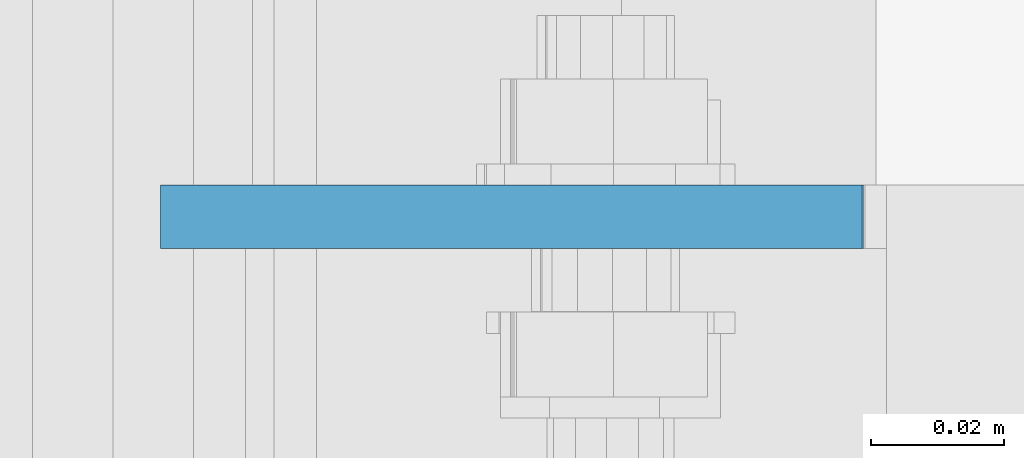
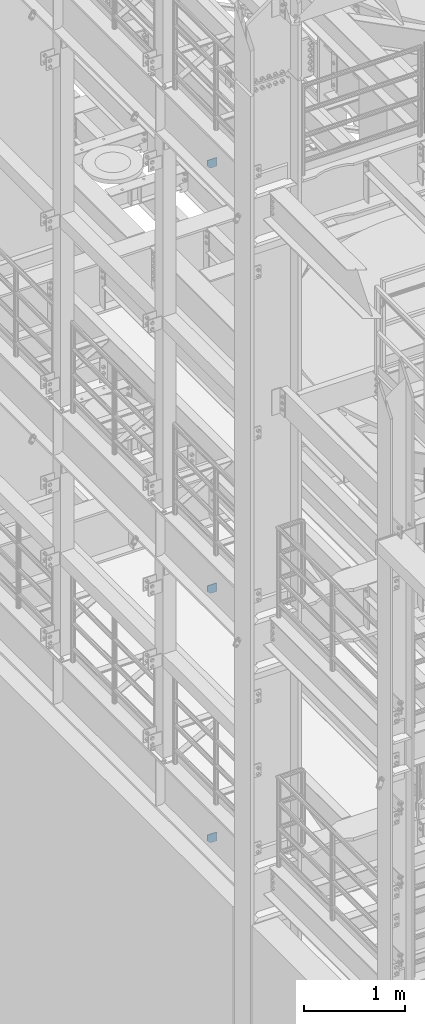
# One storey, part 1477 of 1876: 3 plates, 3 elements without a shape of their own.
"""IFC2X3 building model written with IfcOpenShell, lengths in millimetres."""

from ifc_helpers import new_model, si_unit, frame, origin_with_axes, place, context, subcontext, project, spatial, faceted_brep, material, type_object, element, aggregate, save


model = new_model("IFC2X3")

# Units and contexts
model_context = context("Model", 3, precision=1e-05, world=origin_with_axes())
body_context = subcontext(model_context, "Body", "Model", "MODEL_VIEW")
ifc_project = project(units=[si_unit("LENGTHUNIT", "METRE", prefix="MILLI"), si_unit("AREAUNIT", "SQUARE_METRE"), si_unit("VOLUMEUNIT", "CUBIC_METRE"), si_unit("MASSUNIT", "GRAM", prefix="KILO"), si_unit("TIMEUNIT", "SECOND"), si_unit("PLANEANGLEUNIT", "RADIAN"), si_unit("SOLIDANGLEUNIT", "STERADIAN"), si_unit("THERMODYNAMICTEMPERATUREUNIT", "DEGREE_CELSIUS"), si_unit("LUMINOUSINTENSITYUNIT", "LUMEN")], contexts=[model_context])

# Site, building, storey
site_placement = place(None, origin_with_axes())
site = spatial("IfcSite", under=ifc_project, at=site_placement, CompositionType="ELEMENT")
building_placement = place(site_placement, origin_with_axes())
building = spatial("IfcBuilding", under=site, at=building_placement, Name="Undefined", CompositionType="ELEMENT")
storey_placement = place(building_placement, origin_with_axes())
storey = spatial("IfcBuildingStorey", under=building, at=storey_placement, Name="Undefined", CompositionType="ELEMENT", Elevation=0.0)

# Assembly, plate
assembly_1_placement = place(storey_placement, origin_with_axes())
assembly_1 = element("IfcElementAssembly", 1, at=assembly_1_placement, inside=storey, Name="BEAM", AssemblyPlace="NOTDEFINED", PredefinedType="RIGID_FRAME")
ifc_material = material(Name="STEEL/A36")
plate_type_1 = type_object("IfcPlateType", PredefinedType="NOTDEFINED")
plate_1_placement = place(assembly_1_placement, frame((7.14374663736635, -3357.56250000001, 12816.9742795603), z_axis=(0.0, 0.0, -1.0), x_axis=(1.0, 0.0, 0.0)))
plate_1 = element("IfcPlate", 2, at=plate_1_placement, type_object=plate_type_1, material=ifc_material, Name="PLATE", context=body_context, shape_type="Brep", body=[
    faceted_brep([(0.0, -4.76249999999982, 0.0), (3.36263383360347e-06, -4.76249999999999, 72.5242767333984), (3.36263383360347e-06, 4.76249999999999, 72.5242767333984), (0.0, 4.76249999999982, 0.0), (31.7500038146972, -4.76249999999999, 104.274276733398), (31.7500038146972, 4.76249999999999, 104.274276733398), (105.092643737793, -4.76249999999999, 104.274276733398), (105.092643737793, 4.76249999999999, 104.274276733398), (105.092643737793, -4.76249999999999, 0.0), (105.092643737793, 4.76249999999999, 0.0)], [[[0, 1, 2, 3]], [[1, 4, 5, 2]], [[4, 6, 7, 5]], [[6, 8, 9, 7]], [[8, 0, 3, 9]], [[5, 7, 9, 3, 2]], [[8, 6, 4, 1, 0]]]),
])
aggregate(assembly_1, [plate_1])

assembly_2_placement = place(storey_placement, origin_with_axes())
assembly_2 = element("IfcElementAssembly", 3, at=assembly_2_placement, inside=storey, Name="BEAM", AssemblyPlace="NOTDEFINED", PredefinedType="RIGID_FRAME")
plate_type_2 = type_object("IfcPlateType", PredefinedType="NOTDEFINED")
plate_2_placement = place(assembly_2_placement, frame((7.14375, -3357.5625, 7556.5), z_axis=(0.0, 0.0, 1.0), x_axis=(1.0, 0.0, 0.0)))
plate_2 = element("IfcPlate", 4, at=plate_2_placement, type_object=plate_type_2, material=ifc_material, Name="PLATE", context=body_context, shape_type="Brep", body=[
    faceted_brep([(-9.76996261670138e-14, -4.76250000000073, 31.75), (0.0, -4.76249999999999, 103.486999511719), (0.0, 4.76249999999999, 103.486999511719), (-9.76996261670138e-14, 4.76250000000073, 31.75), (105.307250976562, -4.76249999999982, 103.486999511719), (105.307250976562, 4.76249999999982, 103.486999511719), (105.307250976562, -4.76249999999999, 0.0), (105.307250976562, 4.76249999999999, 0.0), (31.75, -4.76250000000073, 0.0), (31.75, 4.76250000000073, 0.0)], [[[0, 1, 2, 3]], [[1, 4, 5, 2]], [[4, 6, 7, 5]], [[6, 8, 9, 7]], [[8, 0, 3, 9]], [[5, 7, 9, 3, 2]], [[8, 6, 4, 1, 0]]]),
])
aggregate(assembly_2, [plate_2])

assembly_3_placement = place(storey_placement, origin_with_axes())
assembly_3 = element("IfcElementAssembly", 5, at=assembly_3_placement, inside=storey, Name="BEAM", AssemblyPlace="NOTDEFINED", PredefinedType="RIGID_FRAME")
plate_3_placement = place(assembly_3_placement, frame((112.451000275038, -3357.5625, 4637.38699830036), z_axis=(0.0, 0.0, -1.0), x_axis=(-1.0, 0.0, 0.0)))
plate_3 = element("IfcPlate", 6, at=plate_3_placement, type_object=plate_type_2, material=ifc_material, Name="PLATE", context=body_context, shape_type="Brep", body=[
    faceted_brep([(0.0, -4.76249999999982, 0.0), (0.0, -4.76249999999999, 103.486999511719), (0.0, 4.76249999999999, 103.486999511719), (0.0, 4.76249999999982, 0.0), (73.5572509765625, -4.76249999999999, 103.486999511719), (73.5572509765625, 4.76249999999999, 103.486999511719), (105.307250976562, -4.76249999999999, 71.7369995117188), (105.307250976562, 4.76249999999999, 71.7369995117188), (105.307250976562, -4.76249999999999, 0.0), (105.307250976562, 4.76249999999999, 0.0)], [[[0, 1, 2, 3]], [[1, 4, 5, 2]], [[4, 6, 7, 5]], [[6, 8, 9, 7]], [[8, 0, 3, 9]], [[5, 7, 9, 3, 2]], [[8, 6, 4, 1, 0]]]),
])
aggregate(assembly_3, [plate_3])

save(model, "model.ifc")
